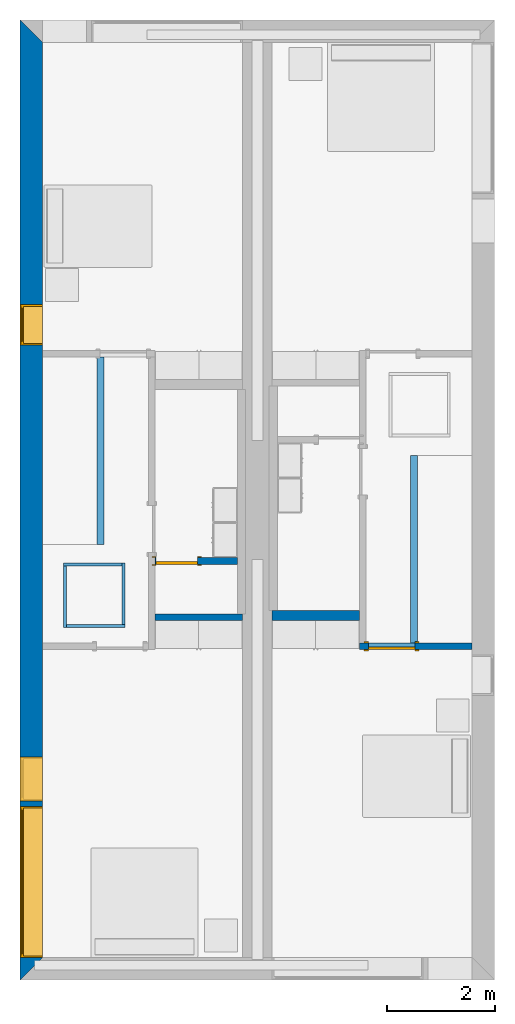
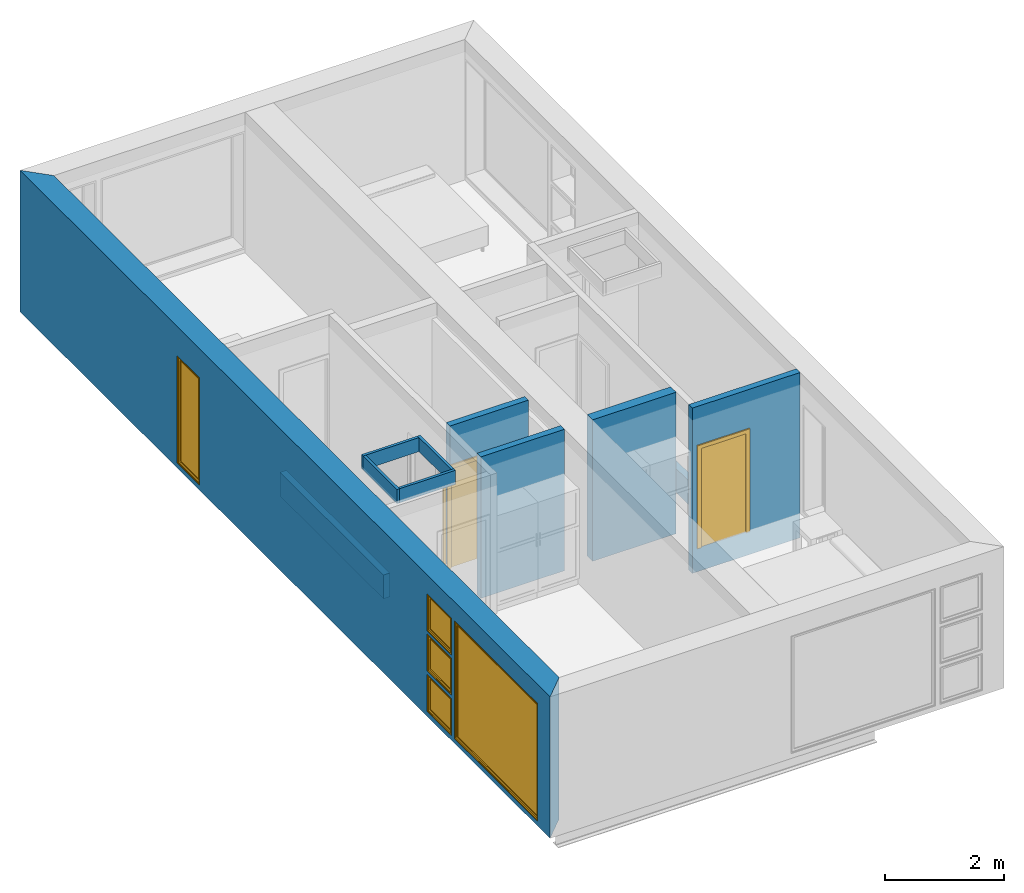
# One storey, part 2 of 10: 11 walls, 5 windows, 2 doors, 9 openings.
"""IFC2X3 building model written with IfcOpenShell, lengths in metres."""

from ifc_helpers import new_model, entity, si_unit, converted_unit, derived_unit, direction, frame, frame_2d, origin, origin_2d_with_axis, place, context, subcontext, project, spatial, polyline, rectangle, outline, extrude, source, transform, mapped, material, material_list, layer, layer_set, layer_usage, type_object, type_shapes, element, fill, save


model = new_model("IFC2X3")

# Units and contexts
model_context = context("Model", 3, precision=1e-05, world=origin(), true_north=direction((6.12303176911189e-17, 1.0)))
body_context = subcontext(model_context, "Body", "Model", "MODEL_VIEW")
ifc_project = project(units=[derived_unit("USERDEFINED", [(si_unit("LENGTHUNIT", "METRE"), -2), (si_unit("TIMEUNIT", "SECOND"), -2), (si_unit("MASSUNIT", "GRAM", prefix="KILO"), 1)]), si_unit("FREQUENCYUNIT", "HERTZ"), si_unit("LENGTHUNIT", "METRE"), si_unit("ILLUMINANCEUNIT", "LUX"), derived_unit("LINEARVELOCITYUNIT", [(si_unit("TIMEUNIT", "SECOND"), -1), (si_unit("LENGTHUNIT", "METRE"), 1)]), si_unit("POWERUNIT", "WATT"), si_unit("LUMINOUSINTENSITYUNIT", "CANDELA"), si_unit("AREAUNIT", "SQUARE_METRE"), si_unit("VOLUMEUNIT", "CUBIC_METRE"), si_unit("ELECTRICVOLTAGEUNIT", "VOLT"), si_unit("PRESSUREUNIT", "PASCAL"), converted_unit("PLANEANGLEUNIT", "DEGREE", entity("IfcRatioMeasure", 0.0174532925199433), si_unit("PLANEANGLEUNIT", "RADIAN"), dimensions=[0, 0, 0, 0, 0, 0, 0]), si_unit("THERMODYNAMICTEMPERATUREUNIT", "DEGREE_CELSIUS"), si_unit("MASSUNIT", "GRAM", prefix="KILO"), derived_unit("VOLUMETRICFLOWRATEUNIT", [(si_unit("LENGTHUNIT", "METRE"), 3), (si_unit("TIMEUNIT", "SECOND"), -1)]), si_unit("TIMEUNIT", "SECOND"), si_unit("LUMINOUSFLUXUNIT", "LUMEN"), derived_unit("USERDEFINED", [(si_unit("LUMINOUSFLUXUNIT", "LUMEN"), 1), (si_unit("TIMEUNIT", "SECOND"), 3), (si_unit("MASSUNIT", "GRAM", prefix="KILO"), -1), (si_unit("LENGTHUNIT", "METRE"), -2)]), si_unit("FORCEUNIT", "NEWTON", prefix="KILO"), si_unit("ELECTRICCURRENTUNIT", "AMPERE"), derived_unit("THERMALTRANSMITTANCEUNIT", [(si_unit("TIMEUNIT", "SECOND"), -3), (si_unit("THERMODYNAMICTEMPERATUREUNIT", "KELVIN"), -1), (si_unit("MASSUNIT", "GRAM", prefix="KILO"), 1)])], contexts=[model_context])

# Site, building, storey
site_placement = place(None, origin())
site = spatial("IfcSite", under=ifc_project, at=site_placement, CompositionType="ELEMENT")
building_placement = place(site_placement, origin())
building = spatial("IfcBuilding", under=site, at=building_placement, CompositionType="ELEMENT")
storey_placement = place(building_placement, frame((0.0, 0.0, 3.10000000000038)))
storey = spatial("IfcBuildingStorey", under=building, at=storey_placement, Name="Level 2", CompositionType="ELEMENT", Elevation=3.10000000000038)

# Wall, openings, windows
ifc_material_1 = material(Name="Masonry - Brick")
ifc_layer_1 = layer(ifc_material_1, 0.092)
ifc_material_2 = material(Name="Misc. Air Layers - Air Space")
ifc_layer_2 = layer(ifc_material_2, 0.025)
ifc_material_3 = material(Name="Insulation / Thermal Barriers - Rigid insulation")
ifc_layer_3 = layer(ifc_material_3, 0.05)
ifc_material_4 = material(Name="Masonry - Concrete Block")
ifc_layer_4 = layer(ifc_material_4, 0.193)
ifc_material_5 = material(Name="Metal - Stud Layer")
ifc_layer_5 = layer(ifc_material_5, 0.041)
ifc_material_6 = material(Name="Plasterboard")
ifc_layer_6 = layer(ifc_material_6, 0.016)
ifc_layer_set_1 = layer_set([ifc_layer_1, ifc_layer_2, ifc_layer_3, ifc_layer_4, ifc_layer_5, ifc_layer_6], Name="Mur de base:Exterior - Brick on Block")
ifc_layer_usage_1 = layer_usage(ifc_layer_set_1, "AXIS2", "NEGATIVE", 0.2085)
wall_type_1 = type_object("IfcWallType", Name="Mur de base:Exterior - Brick on Block", PredefinedType="STANDARD", material=ifc_layer_set_1)
wall_1_placement = place(storey_placement, frame((0.208499999999999, -17.8, 0.0), z_axis=(0.0, 0.0, 1.0), x_axis=(0.0, 1.0, 0.0)))
wall_1 = element("IfcWallStandardCase", 1, at=wall_1_placement, inside=storey, type_object=wall_type_1, material=ifc_layer_usage_1, Name="Mur de base:Exterior - Brick on Block", ObjectType="Mur de base:Exterior - Brick on Block", context=body_context, shape_type="SweptSolid", body=[
    extrude(outline(polyline([(17.383, -0.2085), (17.8, 0.2085), (0.0, 0.2085), (0.417, -0.2085), (6.12599999999998, -0.2085), (6.24999999999998, -0.2085), (17.383, -0.2085)])), origin(), (0.0, 0.0, 1.0), 2.90000000000001),
])
opening_1_placement = place(wall_1_placement, origin())
element("IfcOpeningElement", 2, at=opening_1_placement, cuts=wall_1, Name="Mur de base:Exterior - Brick on Block", ObjectType="Opening", context=body_context, shape_type="SweptSolid", body=[
    extrude(rectangle(XDim=0.758999999999998, YDim=0.417, at=frame_2d((0.0, 2.77555756156289e-16), x_axis=(0.0, 1.0))), frame((17.5915, -1.0275, 0.479500000000004), z_axis=(0.0, 1.0, 0.0), x_axis=(-1.0, 0.0, 0.0)), (0.0, 0.0, 1.0), 0.819),
])
opening_2_placement = place(wall_1_placement, origin())
element("IfcOpeningElement", 3, at=opening_2_placement, cuts=wall_1, Name="Mur de base:Exterior - Brick on Block", ObjectType="Opening", context=body_context, shape_type="SweptSolid", body=[
    extrude(rectangle(XDim=0.758999999999999, YDim=0.417, at=frame_2d((0.0, 0.0), x_axis=(0.0, 1.0))), frame((17.5915, -1.0275, 2.1305), z_axis=(0.0, 1.0, 0.0), x_axis=(-1.0, 0.0, 0.0)), (0.0, 0.0, 1.0), 0.819),
])
opening_3_placement = place(wall_1_placement, frame((0.416999999999998, -0.208499999999996, 0.0999999999998186)))
opening_3 = element("IfcOpeningElement", 4, at=opening_3_placement, cuts=wall_1, Name="M_Fixed:2800mm x 2410mm:1", ObjectType="Opening", context=body_context, shape_type="SweptSolid", body=[
    extrude(rectangle(XDim=2.41, YDim=2.8, at=frame_2d((1.205, 1.4), x_axis=(1.0, 0.0))), frame((0.0, 0.0, 0.0), z_axis=(0.0, 1.0, 0.0), x_axis=(0.0, 0.0, 1.0)), (0.0, 0.0, 1.0), 0.417),
])
opening_4_placement = place(wall_1_placement, frame((11.774, -0.2085, 0.0999999999998186)))
opening_4 = element("IfcOpeningElement", 5, at=opening_4_placement, cuts=wall_1, Name="M_Fixed:750mm x 2200mm:1", ObjectType="Opening", context=body_context, shape_type="SweptSolid", body=[
    extrude(rectangle(XDim=2.2, YDim=0.75, at=frame_2d((1.1, 0.374999999999999), x_axis=(1.0, 0.0))), frame((0.0, 0.0, 0.0), z_axis=(0.0, 1.0, 0.0), x_axis=(0.0, 0.0, 1.0)), (0.0, 0.0, 1.0), 0.417),
])
opening_5_placement = place(wall_1_placement, frame((3.317, -0.208499999999999, 1.75099999999982)))
opening_5 = element("IfcOpeningElement", 6, at=opening_5_placement, cuts=wall_1, Name="M_Fixed:819mm x 759mm:1", ObjectType="Opening", context=body_context, shape_type="SweptSolid", body=[
    extrude(rectangle(XDim=0.758999999999998, YDim=0.819, at=frame_2d((0.379499999999999, 0.4095), x_axis=(1.0, 0.0))), frame((0.0, 0.0, 0.0), z_axis=(0.0, 1.0, 0.0), x_axis=(0.0, 0.0, 1.0)), (0.0, 0.0, 1.0), 0.417),
])
opening_6_placement = place(wall_1_placement, frame((3.317, -0.208499999999999, 0.0999999999998186)))
opening_6 = element("IfcOpeningElement", 7, at=opening_6_placement, cuts=wall_1, Name="M_Fixed:819mm x 759mm:1", ObjectType="Opening", context=body_context, shape_type="SweptSolid", body=[
    extrude(rectangle(XDim=0.758999999999998, YDim=0.819, at=frame_2d((0.379499999999999, 0.4095), x_axis=(1.0, 0.0))), frame((0.0, 0.0, 0.0), z_axis=(0.0, 1.0, 0.0), x_axis=(0.0, 0.0, 1.0)), (0.0, 0.0, 1.0), 0.417),
])
opening_7_placement = place(wall_1_placement, frame((3.31700000000001, -0.2085, 0.925499999999818)))
opening_7 = element("IfcOpeningElement", 8, at=opening_7_placement, cuts=wall_1, Name="M_Casement:819mm x 759mm:1", ObjectType="Opening", context=body_context, shape_type="SweptSolid", body=[
    extrude(rectangle(XDim=0.759000000000001, YDim=0.819, at=frame_2d((0.3795, 0.4095), x_axis=(-1.0, 0.0))), frame((0.0, 0.0, 0.0), z_axis=(0.0, 1.0, 0.0), x_axis=(0.0, 0.0, 1.0)), (0.0, 0.0, 1.0), 0.417),
])
ifc_material_7 = material(Name="Glass")
ifc_material_8 = material(Name="Sash")
ifc_material_list_1 = material_list([ifc_material_7, ifc_material_8])
ifc_material_list_2 = material_list([ifc_material_7, ifc_material_8])
window_style_1 = type_object("IfcWindowStyle", Name="750mm x 2200mm", ConstructionType="OTHER_CONSTRUCTION", OperationType="NOTDEFINED", ParameterTakesPrecedence=False, Sizeable=False, material=ifc_material_list_2)
shared_shape_1 = source(origin(), body_context, "Body", "SweptSolid", [
    extrude(outline(polyline([(-0.356, -1.081), (0.356, -1.081), (0.356, 1.081), (-0.356, 1.081), (-0.356, -1.081)]), holes=[polyline([(-0.312, -1.037), (-0.312, 1.037), (0.311999999999997, 1.037), (0.311999999999997, -1.037), (-0.312, -1.037)])]), frame((0.375000000000008, 0.353999999999972, 1.09999999999999), z_axis=(0.0, 1.0, 0.0), x_axis=(1.0, 0.0, 0.0)), (0.0, 0.0, 1.0), 0.0440000000000274),
    extrude(rectangle(XDim=0.012, YDim=0.623999999999997, at=origin_2d_with_axis()), frame((0.375000000000007, 0.375999999999999, 0.0629999999999851), z_axis=(0.0, 0.0, 1.0), x_axis=(0.0, -1.0, 0.0)), (0.0, 0.0, 1.0), 2.07400000000001),
    extrude(outline(polyline([(-0.375, -1.1), (0.375, -1.1), (0.375, 1.1), (-0.375, 1.1), (-0.375, -1.1)]), holes=[polyline([(-0.356000000000001, -1.08099999999998), (-0.356000000000001, 1.08100000000002), (0.355999999999999, 1.08100000000002), (0.355999999999999, -1.08099999999998), (-0.356000000000001, -1.08099999999998)])]), frame((0.375000000000009, 0.353999999999972, 1.10000000000001), z_axis=(0.0, 1.0, 0.0), x_axis=(1.0, 0.0, 0.0)), (0.0, 0.0, 1.0), 0.0630000000000274),
    extrude(outline(polyline([(-0.375, -1.1), (0.375, -1.1), (0.375, 1.1), (-0.375, 1.1), (-0.375, -1.1)]), holes=[polyline([(-0.343, -1.06799999999998), (-0.343, 1.06800000000002), (0.343, 1.06800000000002), (0.343, -1.06799999999998), (-0.343, -1.06799999999998)])]), frame((0.37500000000001, 0.0, 1.10000000000001), z_axis=(0.0, 1.0, 0.0), x_axis=(1.0, 0.0, 0.0)), (0.0, 0.0, 1.0), 0.353999999999973),
])
type_shapes(window_style_1, [shared_shape_1])
window_1_placement = place(opening_4_placement, origin())
window_1 = element("IfcWindow", 9, at=window_1_placement, inside=storey, type_object=window_style_1, material=ifc_material_list_1, Name="M_Fixed:750mm x 2200mm", ObjectType="750mm x 2200mm", OverallHeight=2.2, OverallWidth=0.75, context=body_context, shape_type="MappedRepresentation", body=[
    mapped(shared_shape_1, transform((0.0, 0.0, 0.0), scale=1.0)),
])
fill(opening_4, window_1)
ifc_material_list_3 = material_list([ifc_material_7, ifc_material_8])
ifc_material_list_4 = material_list([ifc_material_7, ifc_material_8])
window_style_2 = type_object("IfcWindowStyle", Name="2800mm x 2410mm", ConstructionType="OTHER_CONSTRUCTION", OperationType="NOTDEFINED", ParameterTakesPrecedence=False, Sizeable=False, material=ifc_material_list_4)
shared_shape_2 = source(origin(), body_context, "Body", "SweptSolid", [
    extrude(outline(polyline([(-1.4, -1.205), (1.4, -1.205), (1.4, 1.205), (-1.4, 1.205), (-1.4, -1.205)]), holes=[polyline([(-1.368, -1.17299999999998), (-1.368, 1.17300000000002), (1.368, 1.17300000000002), (1.368, -1.17299999999998), (-1.368, -1.17299999999998)])]), frame((1.40000000000001, 0.0, 1.20500000000001), z_axis=(0.0, 1.0, 0.0), x_axis=(1.0, 0.0, 0.0)), (0.0, 0.0, 1.0), 0.353999999999973),
    extrude(rectangle(XDim=0.012, YDim=2.674, at=origin_2d_with_axis()), frame((1.40000000000001, 0.375999999999996, 0.0629999999999851), z_axis=(0.0, 0.0, 1.0), x_axis=(0.0, -1.0, 0.0)), (0.0, 0.0, 1.0), 2.284),
    extrude(outline(polyline([(-1.4, -1.205), (1.4, -1.205), (1.4, 1.205), (-1.4, 1.205), (-1.4, -1.205)]), holes=[polyline([(-1.381, -1.18599999999998), (-1.381, 1.18600000000002), (1.381, 1.18600000000002), (1.381, -1.18599999999998), (-1.381, -1.18599999999998)])]), frame((1.40000000000001, 0.353999999999968, 1.20500000000001), z_axis=(0.0, 1.0, 0.0), x_axis=(1.0, 0.0, 0.0)), (0.0, 0.0, 1.0), 0.0630000000000274),
    extrude(outline(polyline([(-1.381, -1.186), (1.381, -1.186), (1.381, 1.186), (-1.381, 1.186), (-1.381, -1.186)]), holes=[polyline([(-1.337, -1.142), (-1.337, 1.142), (1.337, 1.142), (1.337, -1.142), (-1.337, -1.142)])]), frame((1.40000000000001, 0.353999999999968, 1.20499999999999), z_axis=(0.0, 1.0, 0.0), x_axis=(1.0, 0.0, 0.0)), (0.0, 0.0, 1.0), 0.0440000000000274),
])
type_shapes(window_style_2, [shared_shape_2])
window_2_placement = place(opening_3_placement, origin())
window_2 = element("IfcWindow", 10, at=window_2_placement, inside=storey, type_object=window_style_2, material=ifc_material_list_3, Name="M_Fixed:2800mm x 2410mm", ObjectType="2800mm x 2410mm", OverallHeight=2.41, OverallWidth=2.8, context=body_context, shape_type="MappedRepresentation", body=[
    mapped(shared_shape_2, transform((0.0, 0.0, 0.0), scale=1.0)),
])
fill(opening_3, window_2)
ifc_material_list_5 = material_list([ifc_material_7, ifc_material_8])
ifc_material_list_6 = material_list([ifc_material_7, ifc_material_8])
window_style_3 = type_object("IfcWindowStyle", Name="819mm x 759mm", ConstructionType="OTHER_CONSTRUCTION", OperationType="NOTDEFINED", ParameterTakesPrecedence=False, Sizeable=False, material=ifc_material_list_6)
shared_shape_3 = source(origin(), body_context, "Body", "SweptSolid", [
    extrude(outline(polyline([(-0.4095, -0.379499999999997), (0.4095, -0.379499999999997), (0.4095, 0.379499999999997), (-0.4095, 0.379499999999997), (-0.4095, -0.379499999999997)]), holes=[polyline([(-0.390500000000001, -0.360499999999982), (-0.390500000000001, 0.360500000000023), (0.390499999999999, 0.360500000000023), (0.390499999999999, -0.360499999999982), (-0.390500000000001, -0.360499999999982)])]), frame((0.409500000000009, 0.353999999999971, 0.37950000000001), z_axis=(0.0, 1.0, 0.0), x_axis=(1.0, 0.0, 0.0)), (0.0, 0.0, 1.0), 0.0630000000000274),
    extrude(outline(polyline([(-0.4095, -0.379499999999997), (0.4095, -0.379499999999997), (0.4095, 0.379499999999997), (-0.4095, 0.379499999999997), (-0.4095, -0.379499999999997)]), holes=[polyline([(-0.3775, -0.347499999999983), (-0.3775, 0.347500000000021), (0.3775, 0.347500000000021), (0.3775, -0.347499999999983), (-0.3775, -0.347499999999983)])]), frame((0.40950000000001, 0.0, 0.379500000000009), z_axis=(0.0, 1.0, 0.0), x_axis=(1.0, 0.0, 0.0)), (0.0, 0.0, 1.0), 0.353999999999973),
    extrude(outline(polyline([(-0.3905, -0.360500000000003), (0.3905, -0.360500000000003), (0.3905, 0.360500000000003), (-0.3905, 0.360500000000003), (-0.3905, -0.360500000000003)]), holes=[polyline([(-0.3465, -0.316500000000003), (-0.3465, 0.316500000000004), (0.346499999999997, 0.316500000000004), (0.346499999999997, -0.316500000000003), (-0.3465, -0.316500000000003)])]), frame((0.409500000000008, 0.353999999999971, 0.379499999999989), z_axis=(0.0, 1.0, 0.0), x_axis=(1.0, 0.0, 0.0)), (0.0, 0.0, 1.0), 0.0440000000000274),
    extrude(rectangle(XDim=0.012, YDim=0.692999999999997, at=origin_2d_with_axis()), frame((0.409500000000007, 0.375999999999999, 0.0629999999999851), z_axis=(0.0, 0.0, 1.0), x_axis=(0.0, -1.0, 0.0)), (0.0, 0.0, 1.0), 0.633000000000007),
])
type_shapes(window_style_3, [shared_shape_3])
window_3_placement = place(opening_5_placement, origin())
window_3 = element("IfcWindow", 11, at=window_3_placement, inside=storey, type_object=window_style_3, material=ifc_material_list_5, Name="M_Fixed:819mm x 759mm", ObjectType="819mm x 759mm", OverallHeight=0.758999999999998, OverallWidth=0.819, context=body_context, shape_type="MappedRepresentation", body=[
    mapped(shared_shape_3, transform((0.0, 0.0, 0.0), scale=1.0)),
])
fill(opening_5, window_3)
ifc_material_list_7 = material_list([ifc_material_7, ifc_material_8])
window_4_placement = place(opening_6_placement, origin())
window_4 = element("IfcWindow", 12, at=window_4_placement, inside=storey, type_object=window_style_3, material=ifc_material_list_7, Name="M_Fixed:819mm x 759mm", ObjectType="819mm x 759mm", OverallHeight=0.758999999999999, OverallWidth=0.819, context=body_context, shape_type="MappedRepresentation", body=[
    mapped(shared_shape_3, transform((0.0, 0.0, 0.0), scale=1.0)),
])
fill(opening_6, window_4)
ifc_material_9 = material(Name="Trim")
ifc_material_list_8 = material_list([ifc_material_7, ifc_material_8, ifc_material_9])
ifc_material_list_9 = material_list([ifc_material_7, ifc_material_8, ifc_material_9])
window_style_4 = type_object("IfcWindowStyle", Name="819mm x 759mm", ConstructionType="OTHER_CONSTRUCTION", OperationType="NOTDEFINED", ParameterTakesPrecedence=False, Sizeable=False, material=ifc_material_list_9)
shared_shape_4 = source(origin(), body_context, "Body", "SweptSolid", [
    extrude(outline(polyline([(-0.390449999999999, -0.360450000000001), (0.390449999999999, -0.360450000000001), (0.390449999999999, 0.360450000000001), (-0.390449999999999, 0.360450000000001), (-0.390449999999999, -0.360450000000001)]), holes=[polyline([(-0.345999999999998, -0.316000000000002), (-0.345999999999998, 0.316000000000003), (0.346, 0.316000000000003), (0.346, -0.316000000000002), (-0.345999999999998, -0.316000000000002)])]), frame((0.409499999999999, 0.35355, 0.379500000000007), z_axis=(0.0, 1.0, 0.0), x_axis=(1.0, 0.0, 0.0)), (0.0, 0.0, 1.0), 0.04445),
    extrude(outline(polyline([(-0.379500000000002, -0.409499999999999), (0.379500000000002, -0.409499999999999), (0.379500000000002, 0.409499999999999), (-0.379500000000002, 0.409499999999999), (-0.379500000000002, -0.409499999999999)]), holes=[polyline([(-0.360450000000002, -0.390449999999999), (-0.360450000000002, 0.39045), (0.360450000000002, 0.39045), (0.360450000000002, -0.390449999999999), (-0.360450000000002, -0.390449999999999)])]), frame((0.4095, 0.35355, 0.379500000000007), z_axis=(0.0, 1.0, 0.0), x_axis=(0.0, 0.0, -1.0)), (0.0, 0.0, 1.0), 0.06345),
    extrude(rectangle(XDim=0.0127, YDim=0.691999999999998, at=frame_2d((-1.69135538907739e-17, 0.0), x_axis=(1.0, 0.0))), frame((0.4095, 0.375775, 0.063500000000004), z_axis=(0.0, 0.0, 1.0), x_axis=(0.0, 1.0, 0.0)), (0.0, 0.0, 1.0), 0.632000000000004),
    extrude(outline(polyline([(-0.409499999999999, -0.379500000000001), (0.409499999999999, -0.379500000000001), (0.409499999999999, 0.379500000000001), (-0.409499999999999, 0.379500000000001), (-0.409499999999999, -0.379500000000001)]), holes=[polyline([(-0.37775, -0.34775), (-0.37775, 0.347750000000001), (0.377749999999998, 0.347750000000001), (0.377749999999998, -0.34775), (-0.37775, -0.34775)])]), frame((0.409500000000001, 0.0, 0.379500000000008), z_axis=(0.0, 1.0, 0.0), x_axis=(1.0, 0.0, 0.0)), (0.0, 0.0, 1.0), 0.35355),
])
type_shapes(window_style_4, [shared_shape_4])
window_5_placement = place(opening_7_placement, origin())
window_5 = element("IfcWindow", 13, at=window_5_placement, inside=storey, type_object=window_style_4, material=ifc_material_list_8, Name="M_Casement:819mm x 759mm", ObjectType="819mm x 759mm", OverallHeight=0.759000000000001, OverallWidth=0.819, context=body_context, shape_type="MappedRepresentation", body=[
    mapped(shared_shape_4, transform((0.0, 0.0, 0.0), scale=1.0)),
])
fill(opening_7, window_5)

# Wall
ifc_layer_7 = layer(ifc_material_6, 0.016)
ifc_layer_8 = layer(ifc_material_5, 0.092)
ifc_layer_9 = layer(ifc_material_6, 0.016)
ifc_layer_set_2 = layer_set([ifc_layer_7, ifc_layer_8, ifc_layer_9], Name="Mur de base:Interior - Partition (92mm Stud)")
ifc_layer_usage_2 = layer_usage(ifc_layer_set_2, "AXIS2", "NEGATIVE", 0.062)
wall_type_2 = type_object("IfcWallType", Name="Mur de base:Interior - Partition (92mm Stud)", PredefinedType="STANDARD", material=ifc_layer_set_2)
wall_2_placement = place(storey_placement, frame((4.12499999999998, -11.072, 0.0), z_axis=(0.0, 0.0, 1.0), x_axis=(-1.0, 0.0, 0.0)))
element("IfcWallStandardCase", 14, at=wall_2_placement, inside=storey, type_object=wall_type_2, material=ifc_layer_usage_2, Name="Mur de base:Interior - Partition (92mm Stud)", ObjectType="Mur de base:Interior - Partition (92mm Stud)", context=body_context, shape_type="SweptSolid", body=[
    extrude(rectangle(XDim=1.61899999999999, YDim=0.124000000000002, at=frame_2d((0.809499999999995, 6.93889390390723e-17), x_axis=(-1.0, 0.0))), origin(), (0.0, 0.0, 1.0), 2.90000000000001),
])

# Wall, opening, door
ifc_layer_usage_3 = layer_usage(ifc_layer_set_2, "AXIS2", "NEGATIVE", 0.062)
wall_3_placement = place(storey_placement, frame((8.38299999999998, -11.612, -0.488000000000182), z_axis=(0.0, 0.0, 1.0), x_axis=(-1.0, 0.0, 0.0)))
wall_3 = element("IfcWallStandardCase", 15, at=wall_3_placement, inside=storey, type_object=wall_type_2, material=ifc_layer_usage_3, Name="Mur de base:Interior - Partition (92mm Stud)", ObjectType="Mur de base:Interior - Partition (92mm Stud)", context=body_context, shape_type="SweptSolid", body=[
    extrude(rectangle(XDim=2.08899999999998, YDim=0.124000000000002, at=frame_2d((1.04449999999999, 6.24500451351651e-17), x_axis=(-1.0, 0.0))), origin(), (0.0, 0.0, 1.0), 3.38800000000001),
])
opening_8_placement = place(wall_3_placement, frame((1.0617, -0.0620000000000021, 0.488000000000001)))
opening_8 = element("IfcOpeningElement", 16, at=opening_8_placement, cuts=wall_3, Name="M_Single-Flush:0864 x 2032mm:1", ObjectType="Opening", context=body_context, shape_type="SweptSolid", body=[
    extrude(rectangle(XDim=0.863999999999999, YDim=2.032, at=frame_2d((1.016, 0.432), x_axis=(0.0, 1.0))), frame((0.0, 0.0, 0.0), z_axis=(0.0, 1.0, 0.0), x_axis=(0.0, 0.0, 1.0)), (0.0, 0.0, 1.0), 0.124),
])
ifc_material_10 = material(Name="Door - Frame")
ifc_material_11 = material(Name="Door - Panel")
ifc_material_list_10 = material_list([ifc_material_10, ifc_material_11])
ifc_material_list_11 = material_list([ifc_material_10, ifc_material_11])
door_style_1 = type_object("IfcDoorStyle", Name="0864 x 2032mm", ConstructionType="USERDEFINED", OperationType="SINGLE_SWING_RIGHT", ParameterTakesPrecedence=False, Sizeable=False, material=ifc_material_list_11)
shared_shape_5 = source(origin(), body_context, "Body", "SweptSolid", [
    extrude(outline(polyline([(-0.508, -1.073), (0.508, -1.073), (0.508, 1.035), (0.432, 1.035), (0.432, -0.997000000000002), (-0.432, -0.997000000000002), (-0.432, 1.035), (-0.508, 1.035), (-0.508, -1.073)])), frame((0.432000000000001, 0.123999999999999, 1.035), z_axis=(0.0, 1.0, 0.0), x_axis=(1.0, 0.0, 0.0)), (0.0, 0.0, 1.0), 0.0249999999999944),
    extrude(outline(polyline([(-1.073, -0.507999999999997), (1.035, -0.507999999999997), (1.035, -0.432000000000007), (-0.997, -0.432000000000007), (-0.997, 0.432000000000002), (1.035, 0.432000000000002), (1.035, 0.508000000000003), (-1.073, 0.508000000000003), (-1.073, -0.507999999999997)])), frame((0.432000000000003, -0.0250000000000064, 1.035), z_axis=(0.0, 1.0, 0.0), x_axis=(0.0, 0.0, -1.0)), (0.0, 0.0, 1.0), 0.0250000000000056),
    extrude(rectangle(XDim=0.051, YDim=0.864, at=origin_2d_with_axis()), frame((0.432, 0.0984999999999992, 0.0), z_axis=(0.0, 0.0, 1.0), x_axis=(0.0, 1.0, 0.0)), (0.0, 0.0, 1.0), 2.032),
])
type_shapes(door_style_1, [shared_shape_5])
door_1_placement = place(opening_8_placement, origin())
door_1 = element("IfcDoor", 17, at=door_1_placement, inside=storey, type_object=door_style_1, material=ifc_material_list_10, Name="M_Single-Flush:0864 x 2032mm", ObjectType="0864 x 2032mm", OverallHeight=2.032, OverallWidth=0.864, context=body_context, shape_type="MappedRepresentation", body=[
    mapped(shared_shape_5, transform((0.0, 0.0, 0.0), scale=1.0)),
])
fill(opening_8, door_1)

ifc_layer_usage_4 = layer_usage(ifc_layer_set_2, "AXIS2", "NEGATIVE", 0.062)
wall_4_placement = place(storey_placement, frame((4.02999999999998, -10.0320511785106, 0.0), z_axis=(0.0, 0.0, 1.0), x_axis=(-1.0, 0.0, 0.0)))
wall_4 = element("IfcWallStandardCase", 18, at=wall_4_placement, inside=storey, type_object=wall_type_2, material=ifc_layer_usage_4, Name="Mur de base:Interior - Partition (92mm Stud)", ObjectType="Mur de base:Interior - Partition (92mm Stud)", context=body_context, shape_type="SweptSolid", body=[
    extrude(rectangle(XDim=1.52399999999999, YDim=0.124000000000002, at=frame_2d((0.761999999999995, 0.0), x_axis=(-1.0, 0.0))), origin(), (0.0, 0.0, 1.0), 2.90000000000001),
])
opening_9_placement = place(wall_4_placement, frame((0.741999999999986, -0.0619999999999989, 0.0)))
opening_9 = element("IfcOpeningElement", 19, at=opening_9_placement, cuts=wall_4, Name="M_Single-Flush:0762 x 2032mm:1", ObjectType="Opening", context=body_context, shape_type="SweptSolid", body=[
    extrude(rectangle(XDim=0.762, YDim=2.032, at=frame_2d((1.016, 0.381), x_axis=(0.0, 1.0))), frame((0.0, 0.0, 0.0), z_axis=(0.0, 1.0, 0.0), x_axis=(0.0, 0.0, 1.0)), (0.0, 0.0, 1.0), 0.124),
])
ifc_material_list_12 = material_list([ifc_material_10, ifc_material_11])
ifc_material_list_13 = material_list([ifc_material_10, ifc_material_11])
door_style_2 = type_object("IfcDoorStyle", Name="0762 x 2032mm", ConstructionType="USERDEFINED", OperationType="SINGLE_SWING_RIGHT", ParameterTakesPrecedence=False, Sizeable=False, material=ifc_material_list_13)
shared_shape_6 = source(origin(), body_context, "Body", "SweptSolid", [
    extrude(outline(polyline([(-0.457, -1.073), (0.457, -1.073), (0.457, 1.035), (0.381, 1.035), (0.381, -0.997000000000002), (-0.381, -0.997000000000002), (-0.381, 1.035), (-0.457, 1.035), (-0.457, -1.073)])), frame((0.381000000000001, 0.123999999999999, 1.035), z_axis=(0.0, 1.0, 0.0), x_axis=(1.0, 0.0, 0.0)), (0.0, 0.0, 1.0), 0.0249999999999945),
    extrude(outline(polyline([(-1.073, -0.456999999999997), (1.035, -0.456999999999997), (1.035, -0.381000000000007), (-0.997, -0.381000000000007), (-0.997, 0.381000000000002), (1.035, 0.381000000000002), (1.035, 0.457000000000003), (-1.073, 0.457000000000003), (-1.073, -0.456999999999997)])), frame((0.381000000000003, -0.0250000000000063, 1.035), z_axis=(0.0, 1.0, 0.0), x_axis=(0.0, 0.0, -1.0)), (0.0, 0.0, 1.0), 0.0250000000000056),
    extrude(rectangle(XDim=0.051, YDim=0.762, at=origin_2d_with_axis()), frame((0.381, 0.0984999999999993, 0.0), z_axis=(0.0, 0.0, 1.0), x_axis=(0.0, 1.0, 0.0)), (0.0, 0.0, 1.0), 2.032),
])
type_shapes(door_style_2, [shared_shape_6])
door_2_placement = place(opening_9_placement, origin())
door_2 = element("IfcDoor", 20, at=door_2_placement, inside=storey, type_object=door_style_2, material=ifc_material_list_12, Name="M_Single-Flush:0762 x 2032mm", ObjectType="0762 x 2032mm", OverallHeight=2.032, OverallWidth=0.762, context=body_context, shape_type="MappedRepresentation", body=[
    mapped(shared_shape_6, transform((0.0, 0.0, 0.0), scale=1.0)),
])
fill(opening_9, door_2)

# Walls
ifc_layer_usage_5 = layer_usage(ifc_layer_set_2, "AXIS2", "NEGATIVE", 0.062)
wall_5_placement = place(storey_placement, frame((1.49340000000001, -6.25000000000001, -0.488000000000377), z_axis=(0.0, 0.0, 1.0), x_axis=(0.0, -1.0, 0.0)))
element("IfcWallStandardCase", 21, at=wall_5_placement, inside=storey, type_object=wall_type_2, material=ifc_layer_usage_5, Name="Mur de base:Interior - Partition (92mm Stud)", ObjectType="Mur de base:Interior - Partition (92mm Stud)", context=body_context, shape_type="SweptSolid", body=[
    extrude(rectangle(XDim=3.475, YDim=0.124, at=frame_2d((1.7375, 0.0), x_axis=(-1.0, 0.0))), origin(), (0.0, 0.0, 1.0), 0.488000000000196),
])
ifc_layer_usage_6 = layer_usage(ifc_layer_set_2, "AXIS2", "NEGATIVE", 0.062)
wall_6_placement = place(storey_placement, frame((7.30659999999996, -11.55, -0.488000000000377), z_axis=(0.0, 0.0, 1.0), x_axis=(0.0, 1.0, 0.0)))
element("IfcWallStandardCase", 22, at=wall_6_placement, inside=storey, type_object=wall_type_2, material=ifc_layer_usage_6, Name="Mur de base:Interior - Partition (92mm Stud)", ObjectType="Mur de base:Interior - Partition (92mm Stud)", context=body_context, shape_type="SweptSolid", body=[
    extrude(rectangle(XDim=3.475, YDim=0.124, at=frame_2d((1.7375, -2.08166817117217e-16), x_axis=(-1.0, 0.0))), origin(), (0.0, 0.0, 1.0), 0.488000000000196),
])
ifc_layer_10 = layer(ifc_material_6, 0.016)
ifc_layer_11 = layer(ifc_material_5, 0.152)
ifc_layer_12 = layer(ifc_material_6, 0.016)
ifc_layer_set_3 = layer_set([ifc_layer_10, ifc_layer_11, ifc_layer_12], Name="Mur de base:Interior - Plumbing (152mm Stud)")
ifc_layer_usage_7 = layer_usage(ifc_layer_set_3, "AXIS2", "NEGATIVE", 0.092)
wall_type_3 = type_object("IfcWallType", Name="Mur de base:Interior - Plumbing (152mm Stud)", PredefinedType="STANDARD", material=ifc_layer_set_3)
wall_7_placement = place(storey_placement, frame((6.294, -11.042, 0.0), z_axis=(0.0, 0.0, 1.0), x_axis=(-1.0, 0.0, 0.0)))
element("IfcWallStandardCase", 23, at=wall_7_placement, inside=storey, type_object=wall_type_3, material=ifc_layer_usage_7, Name="Mur de base:Interior - Plumbing (152mm Stud)", ObjectType="Mur de base:Interior - Plumbing (152mm Stud)", context=body_context, shape_type="SweptSolid", body=[
    extrude(rectangle(XDim=1.61900000000002, YDim=0.184000000000002, at=frame_2d((0.809500000000009, -7.63278329429795e-17), x_axis=(-1.0, 0.0))), origin(), (0.0, 0.0, 1.0), 2.90000000000001),
])
ifc_layer_13 = layer(ifc_material_5, 0.038)
ifc_layer_14 = layer(ifc_material_6, 0.016)
ifc_layer_set_4 = layer_set([ifc_layer_13, ifc_layer_14], Name="Mur de base:Interior - Furring (38 mm Stud)")
ifc_layer_usage_8 = layer_usage(ifc_layer_set_4, "AXIS2", "NEGATIVE", 0.027)
wall_type_4 = type_object("IfcWallType", Name="Mur de base:Interior - Furring (38 mm Stud)", PredefinedType="STANDARD", material=ifc_layer_set_4)
wall_8_placement = place(storey_placement, frame((0.807450000000026, -10.09745, 2.612)))
element("IfcWallStandardCase", 24, at=wall_8_placement, inside=storey, type_object=wall_type_4, material=ifc_layer_usage_8, Name="Mur de base:Interior - Furring (38 mm Stud)", ObjectType="Mur de base:Interior - Furring (38 mm Stud)", context=body_context, shape_type="SweptSolid", body=[
    extrude(rectangle(XDim=1.0831, YDim=0.0540000000000007, at=frame_2d((0.54155, 0.0), x_axis=(-1.0, 0.0))), origin(), (0.0, 0.0, 1.0), 0.288000000000013),
])
ifc_layer_usage_9 = layer_usage(ifc_layer_set_4, "AXIS2", "NEGATIVE", 0.027)
wall_9_placement = place(storey_placement, frame((0.834450000000026, -11.25955, 2.612), z_axis=(0.0, 0.0, 1.0), x_axis=(0.0, 1.0, 0.0)))
element("IfcWallStandardCase", 25, at=wall_9_placement, inside=storey, type_object=wall_type_4, material=ifc_layer_usage_9, Name="Mur de base:Interior - Furring (38 mm Stud)", ObjectType="Mur de base:Interior - Furring (38 mm Stud)", context=body_context, shape_type="SweptSolid", body=[
    extrude(rectangle(XDim=1.13509999999996, YDim=0.0539999999999999, at=frame_2d((0.567549999999978, 0.0), x_axis=(-1.0, 0.0))), origin(), (0.0, 0.0, 1.0), 0.288000000000013),
])
ifc_layer_usage_10 = layer_usage(ifc_layer_set_4, "AXIS2", "NEGATIVE", 0.027)
wall_10_placement = place(storey_placement, frame((1.94455000000003, -11.23255, 2.612), z_axis=(0.0, 0.0, 1.0), x_axis=(-1.0, 0.0, 0.0)))
element("IfcWallStandardCase", 26, at=wall_10_placement, inside=storey, type_object=wall_type_4, material=ifc_layer_usage_10, Name="Mur de base:Interior - Furring (38 mm Stud)", ObjectType="Mur de base:Interior - Furring (38 mm Stud)", context=body_context, shape_type="SweptSolid", body=[
    extrude(rectangle(XDim=1.0831, YDim=0.0540000000000007, at=frame_2d((0.54155, -6.59194920871187e-17), x_axis=(-1.0, 0.0))), origin(), (0.0, 0.0, 1.0), 0.288000000000013),
])
ifc_layer_usage_11 = layer_usage(ifc_layer_set_4, "AXIS2", "NEGATIVE", 0.027)
wall_11_placement = place(storey_placement, frame((1.91755000000003, -10.07045, 2.612), z_axis=(0.0, 0.0, 1.0), x_axis=(0.0, -1.0, 0.0)))
element("IfcWallStandardCase", 27, at=wall_11_placement, inside=storey, type_object=wall_type_4, material=ifc_layer_usage_11, Name="Mur de base:Interior - Furring (38 mm Stud)", ObjectType="Mur de base:Interior - Furring (38 mm Stud)", context=body_context, shape_type="SweptSolid", body=[
    extrude(rectangle(XDim=1.13509999999996, YDim=0.0540000000000002, at=frame_2d((0.567549999999979, 0.0), x_axis=(-1.0, 0.0))), origin(), (0.0, 0.0, 1.0), 0.288000000000013),
])

save(model, "model.ifc")
